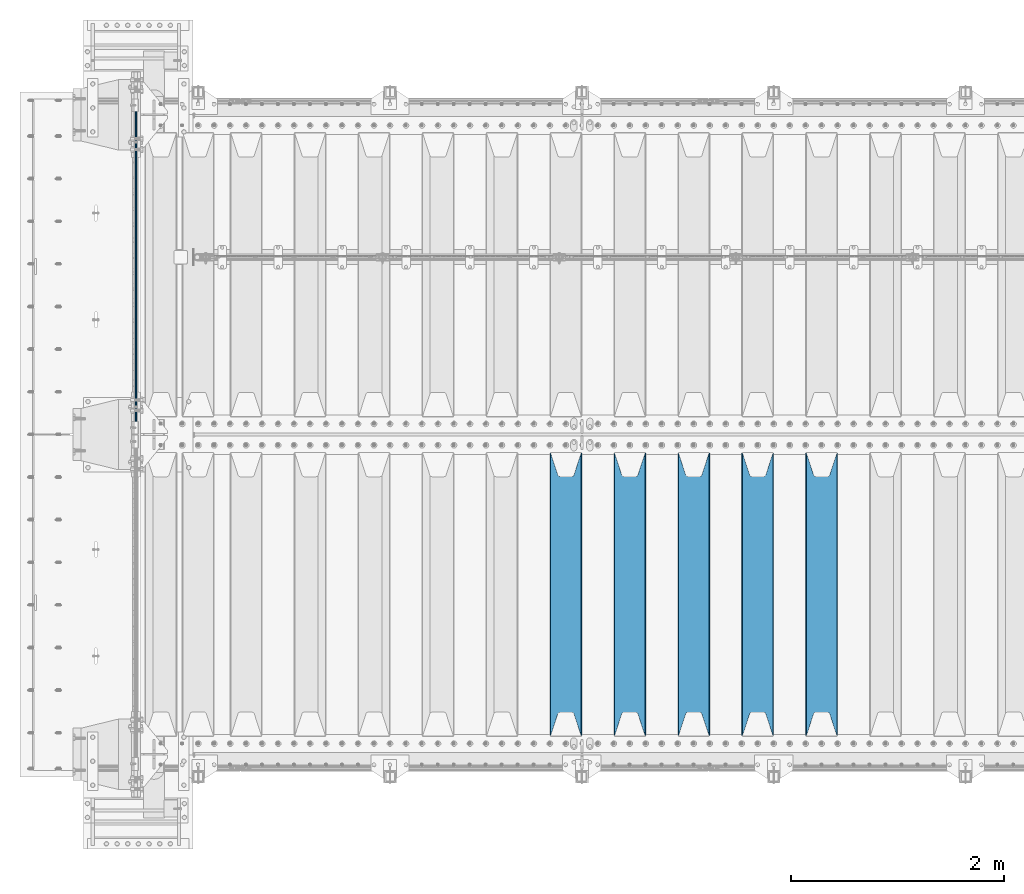
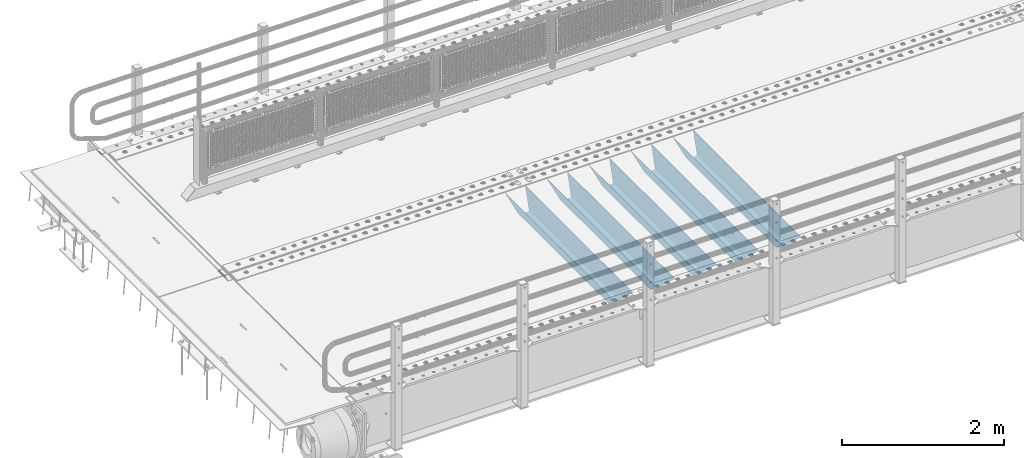
# One storey, part 87 of 193: 6 beams.
"""IFC2X3 building model written with IfcOpenShell, lengths in millimetres."""

from ifc_helpers import new_model, si_unit, frame, origin_with_axes, place, context, subcontext, project, spatial, faceted_brep, material, type_object, element, save


model = new_model("IFC2X3")

# Units and contexts
model_context = context("Model", 3, precision=1e-05, world=origin_with_axes())
body_context = subcontext(model_context, "Body", "Model", "MODEL_VIEW")
ifc_project = project(units=[si_unit("LENGTHUNIT", "METRE", prefix="MILLI"), si_unit("AREAUNIT", "SQUARE_METRE"), si_unit("VOLUMEUNIT", "CUBIC_METRE"), si_unit("MASSUNIT", "GRAM", prefix="KILO"), si_unit("TIMEUNIT", "SECOND"), si_unit("PLANEANGLEUNIT", "RADIAN"), si_unit("SOLIDANGLEUNIT", "STERADIAN"), si_unit("THERMODYNAMICTEMPERATUREUNIT", "DEGREE_CELSIUS"), si_unit("LUMINOUSINTENSITYUNIT", "LUMEN")], contexts=[model_context])

# Site, building, storey
site_placement = place(None, origin_with_axes())
site = spatial("IfcSite", under=ifc_project, at=site_placement, CompositionType="ELEMENT")
building_placement = place(site_placement, origin_with_axes())
building = spatial("IfcBuilding", under=site, at=building_placement, Name="Standard", CompositionType="ELEMENT")
storey_placement = place(building_placement, origin_with_axes())
storey = spatial("IfcBuildingStorey", under=building, at=storey_placement, Name="Undefined", CompositionType="ELEMENT", Elevation=0.0)

# Beams
ifc_material = material(Name="STEEL/S355N")
beam_type_1 = type_object("IfcBeamType", Name="D20", PredefinedType="NOTDEFINED")
beam_1_placement = place(storey_placement, frame((-42485.0, 27005.0, -25.9999999971316), z_axis=(0.0, 0.0, 1.0), x_axis=(0.0, 1.0, 0.0)))
element("IfcBeam", 1, at=beam_1_placement, inside=storey, type_object=beam_type_1, material=ifc_material, ObjectType="D20", context=body_context, shape_type="Brep", body=[
    faceted_brep([(0.0, -10.0, 0.0), (0.0, -7.07106781186303, -7.07106781186548), (3145.0, -7.07106781186303, -7.07106781186548), (3145.0, -10.0, 0.0), (0.0, 0.0, -10.0), (3145.0, 0.0, -10.0), (0.0, 7.07106781186303, -7.07106781186547), (3145.0, 7.07106781186303, -7.07106781186547), (0.0, 10.0, 0.0), (3145.0, 10.0, 0.0), (0.0, 7.07106781186303, 7.07106781186548), (3145.0, 7.07106781186303, 7.07106781186548), (0.0, 0.0, 10.0), (3145.0, 0.0, 10.0), (0.0, -7.07106781186303, 7.07106781186548), (3145.0, -7.07106781186303, 7.07106781186548)], [[[0, 1, 2, 3]], [[1, 4, 5, 2]], [[4, 6, 7, 5]], [[6, 8, 9, 7]], [[8, 10, 11, 9]], [[10, 12, 13, 11]], [[12, 14, 15, 13]], [[14, 0, 3, 15]], [[5, 7, 9, 11, 13, 15, 3, 2]], [[14, 12, 10, 8, 6, 4, 1, 0]]]),
])
beam_type_2 = type_object("IfcBeamType", PredefinedType="NOTDEFINED")
beam_2_placement = place(storey_placement, frame((-36050.0, 24175.0, -115.0), z_axis=(0.0, 0.0, 1.0), x_axis=(0.0, 1.0, 0.0)))
element("IfcBeam", 2, at=beam_2_placement, inside=storey, type_object=beam_type_2, material=ifc_material, context=body_context, shape_type="Brep", body=[
    faceted_brep([(0.0, 150.0, 115.0), (0.0, 143.689999999999, 115.0), (2650.00000000297, 143.689999999999, 115.0), (2650.00000000297, 150.0, 115.0), (2650.00000000297, 142.059565218398, 110.000000003094), (2650.00000000297, 148.3695652184, 110.000000003094), (2441.90079219209, -80.1103600731112, -98.0992078077845), (2437.7588105432, -77.5672621345584, -102.241189456673), (2434.06523489747, -74.4080125315522, -105.934765102404), (2430.9108609509, -70.710272125576, -109.089139048974), (2428.37322971128, -66.5649389910068, -111.626770288588), (2426.51472138055, -62.0739139532889, -113.485278619323), (2425.38102192092, -57.3475956567672, -114.618978078955), (2424.99999999988, -52.5021667386536, -115.0), (2424.99999999988, 52.5021667386536, -115.0), (2425.38102192092, 57.3475956567672, -114.618978078955), (2426.51472138055, 62.0739139532889, -113.485278619323), (2428.37322971128, 66.5649389910068, -111.626770288588), (2430.9108609509, 70.710272125576, -109.089139048974), (2434.06523489747, 74.4080125315522, -105.934765102404), (2437.7588105432, 77.5672621345584, -102.241189456673), (2441.90079219209, 80.1103600731112, -98.0992078077846), (2446.38936140512, 81.9747917625791, -93.6106385947584), (2448.2494850041, 76.2713538057251, -91.7505149957729), (2444.62967112263, 74.76777986261, -95.3703288772456), (2441.28936334127, 72.7168944282894, -98.710636658607), (2438.31067330439, 70.1691124903846, -101.689326695487), (2435.76682334748, 67.1870637758839, -104.233176652398), (2433.72034654134, 63.8440531834895, -106.279653458539), (2432.22154950042, 60.222258798236, -107.778450499454), (2431.30727574265, 56.4107117849089, -108.692724257221), (2430.99999999987, 52.5031078186876, -109.0), (2430.99999999987, -52.5031078186876, -109.0), (2431.30727574265, -56.4107117849089, -108.692724257221), (2432.22154950042, -60.222258798236, -107.778450499454), (2433.72034654134, -63.8440531834895, -106.279653458539), (2435.76682334748, -67.1870637758839, -104.233176652398), (2438.31067330439, -70.1691124903846, -101.689326695487), (2441.28936334127, -72.7168944282894, -98.7106366586071), (2444.62967112263, -74.76777986261, -95.3703288772457), (2448.2494850041, -76.2713538057251, -91.7505149957729), (2650.00000000297, -142.059565218398, 110.000000003094), (2650.00000000297, -148.3695652184, 110.000000003094), (2446.38936140512, -81.9747917625791, -93.6106385947584), (2650.00000000297, -143.689999999999, 115.0), (2650.00000000297, -150.0, 115.0), (0.0, -143.689999999999, 115.0), (0.0, -150.0, 115.0), (0.0, -148.369565218261, 110.000000002667), (203.610638597427, -81.9747917625791, -93.6106385947584), (208.099207810446, -80.1103600731112, -98.0992078077845), (212.241189459342, -77.5672621345584, -102.241189456673), (215.93476510507, -74.4080125315522, -105.934765102404), (219.089139051641, -70.710272125576, -109.089139048974), (221.626770291256, -66.5649389910068, -111.626770288588), (223.485278621989, -62.0739139532889, -113.485278619323), (224.618978081624, -57.3475956567672, -114.618978078955), (225.000000002663, -52.5021667386536, -115.0), (225.000000002663, 52.5021667386536, -115.0), (224.618978081624, 57.3475956567672, -114.618978078955), (223.485278621989, 62.0739139532889, -113.485278619323), (221.626770291256, 66.5649389910068, -111.626770288588), (219.089139051641, 70.710272125576, -109.089139048974), (215.93476510507, 74.4080125315522, -105.934765102404), (212.241189459342, 77.5672621345584, -102.241189456673), (208.099207810446, 80.1103600731112, -98.0992078077846), (203.610638597427, 81.9747917625791, -93.6106385947584), (0.0, 148.369565218261, 110.000000002667), (0.0, 142.05956521826, 110.000000002667), (201.750514998439, 76.2713538057251, -91.7505149957729), (205.370328879915, 74.76777986261, -95.3703288772456), (208.710636661275, 72.7168944282894, -98.710636658607), (211.689326698157, 70.1691124903846, -101.689326695487), (214.233176655063, 67.1870637758839, -104.233176652398), (216.279653461206, 63.8440531834895, -106.279653458539), (217.778450502123, 60.222258798236, -107.778450499454), (218.69272425989, 56.4107117849089, -108.692724257221), (219.00000000267, 52.5031078186876, -109.0), (219.00000000267, -52.5031078186876, -109.0), (218.69272425989, -56.4107117849089, -108.692724257221), (217.778450502123, -60.222258798236, -107.778450499454), (216.279653461206, -63.8440531834895, -106.279653458539), (214.233176655063, -67.1870637758839, -104.233176652398), (211.689326698157, -70.1691124903846, -101.689326695487), (208.710636661275, -72.7168944282894, -98.7106366586071), (205.370328879915, -74.76777986261, -95.3703288772457), (201.750514998439, -76.2713538057251, -91.7505149957729), (0.0, -142.05956521826, 110.000000002667)], [[[0, 1, 2, 3]], [[3, 2, 4, 5]], [[6, 7, 8, 9, 10, 11, 12, 13, 14, 15, 16, 17, 18, 19, 20, 21, 22, 5, 4, 23, 24, 25, 26, 27, 28, 29, 30, 31, 32, 33, 34, 35, 36, 37, 38, 39, 40, 41, 42, 43]], [[44, 45, 42, 41]], [[46, 47, 45, 44]], [[43, 42, 45, 47, 48, 49]], [[6, 43, 49, 50]], [[7, 6, 50, 51]], [[8, 7, 51, 52]], [[9, 8, 52, 53]], [[10, 9, 53, 54]], [[11, 10, 54, 55]], [[12, 11, 55, 56]], [[13, 12, 56, 57]], [[14, 13, 57, 58]], [[15, 14, 58, 59]], [[16, 15, 59, 60]], [[17, 16, 60, 61]], [[18, 17, 61, 62]], [[19, 18, 62, 63]], [[20, 19, 63, 64]], [[21, 20, 64, 65]], [[22, 21, 65, 66]], [[0, 3, 5, 22, 66, 67]], [[1, 0, 67, 68]], [[23, 4, 2, 1, 68, 69]], [[24, 23, 69, 70]], [[25, 24, 70, 71]], [[26, 25, 71, 72]], [[27, 26, 72, 73]], [[28, 27, 73, 74]], [[29, 28, 74, 75]], [[30, 29, 75, 76]], [[31, 30, 76, 77]], [[32, 31, 77, 78]], [[33, 32, 78, 79]], [[34, 33, 79, 80]], [[35, 34, 80, 81]], [[36, 35, 81, 82]], [[37, 36, 82, 83]], [[38, 37, 83, 84]], [[39, 38, 84, 85]], [[40, 39, 85, 86]], [[46, 44, 41, 40, 86, 87]], [[47, 46, 87, 48]], [[86, 85, 84, 83, 82, 81, 80, 79, 78, 77, 76, 75, 74, 73, 72, 71, 70, 69, 68, 67, 66, 65, 64, 63, 62, 61, 60, 59, 58, 57, 56, 55, 54, 53, 52, 51, 50, 49, 48, 87]]]),
])
beam_3_placement = place(storey_placement, frame((-36650.0, 24175.0, -115.0), z_axis=(0.0, 0.0, 1.0), x_axis=(0.0, 1.0, 0.0)))
element("IfcBeam", 3, at=beam_3_placement, inside=storey, type_object=beam_type_2, material=ifc_material, context=body_context, shape_type="Brep", body=[
    faceted_brep([(0.0, 150.0, 115.0), (0.0, 143.689999999999, 115.0), (2650.00000000297, 143.689999999999, 115.0), (2650.00000000297, 150.0, 115.0), (2650.00000000297, 142.059565218398, 110.000000003094), (2650.00000000297, 148.3695652184, 110.000000003094), (2441.90079219209, -80.1103600731112, -98.0992078077845), (2437.7588105432, -77.5672621345584, -102.241189456673), (2434.06523489747, -74.4080125315522, -105.934765102404), (2430.9108609509, -70.710272125576, -109.089139048974), (2428.37322971128, -66.5649389910068, -111.626770288588), (2426.51472138055, -62.0739139532889, -113.485278619323), (2425.38102192092, -57.3475956567672, -114.618978078955), (2424.99999999988, -52.5021667386536, -115.0), (2424.99999999988, 52.5021667386536, -115.0), (2425.38102192092, 57.3475956567672, -114.618978078955), (2426.51472138055, 62.0739139532889, -113.485278619323), (2428.37322971128, 66.5649389910068, -111.626770288588), (2430.9108609509, 70.710272125576, -109.089139048974), (2434.06523489747, 74.4080125315522, -105.934765102404), (2437.7588105432, 77.5672621345584, -102.241189456673), (2441.90079219209, 80.1103600731112, -98.0992078077846), (2446.38936140512, 81.9747917625791, -93.6106385947584), (2448.2494850041, 76.2713538057251, -91.7505149957729), (2444.62967112263, 74.76777986261, -95.3703288772456), (2441.28936334127, 72.7168944282894, -98.710636658607), (2438.31067330439, 70.1691124903846, -101.689326695487), (2435.76682334748, 67.1870637758839, -104.233176652398), (2433.72034654134, 63.8440531834895, -106.279653458539), (2432.22154950042, 60.222258798236, -107.778450499454), (2431.30727574265, 56.4107117849089, -108.692724257221), (2430.99999999987, 52.5031078186876, -109.0), (2430.99999999987, -52.5031078186876, -109.0), (2431.30727574265, -56.4107117849089, -108.692724257221), (2432.22154950042, -60.222258798236, -107.778450499454), (2433.72034654134, -63.8440531834895, -106.279653458539), (2435.76682334748, -67.1870637758839, -104.233176652398), (2438.31067330439, -70.1691124903846, -101.689326695487), (2441.28936334127, -72.7168944282894, -98.7106366586071), (2444.62967112263, -74.76777986261, -95.3703288772457), (2448.2494850041, -76.2713538057251, -91.7505149957729), (2650.00000000297, -142.059565218398, 110.000000003094), (2650.00000000297, -148.3695652184, 110.000000003094), (2446.38936140512, -81.9747917625791, -93.6106385947584), (2650.00000000297, -143.689999999999, 115.0), (2650.00000000297, -150.0, 115.0), (0.0, -143.689999999999, 115.0), (0.0, -150.0, 115.0), (0.0, -148.369565218261, 110.000000002667), (203.610638597427, -81.9747917625791, -93.6106385947584), (208.099207810446, -80.1103600731112, -98.0992078077845), (212.241189459342, -77.5672621345584, -102.241189456673), (215.93476510507, -74.4080125315522, -105.934765102404), (219.089139051641, -70.710272125576, -109.089139048974), (221.626770291256, -66.5649389910068, -111.626770288588), (223.485278621989, -62.0739139532889, -113.485278619323), (224.618978081624, -57.3475956567672, -114.618978078955), (225.000000002663, -52.5021667386536, -115.0), (225.000000002663, 52.5021667386536, -115.0), (224.618978081624, 57.3475956567672, -114.618978078955), (223.485278621989, 62.0739139532889, -113.485278619323), (221.626770291256, 66.5649389910068, -111.626770288588), (219.089139051641, 70.710272125576, -109.089139048974), (215.93476510507, 74.4080125315522, -105.934765102404), (212.241189459342, 77.5672621345584, -102.241189456673), (208.099207810446, 80.1103600731112, -98.0992078077846), (203.610638597427, 81.9747917625791, -93.6106385947584), (0.0, 148.369565218261, 110.000000002667), (0.0, 142.05956521826, 110.000000002667), (201.750514998439, 76.2713538057251, -91.7505149957729), (205.370328879915, 74.76777986261, -95.3703288772456), (208.710636661275, 72.7168944282894, -98.710636658607), (211.689326698157, 70.1691124903846, -101.689326695487), (214.233176655063, 67.1870637758839, -104.233176652398), (216.279653461206, 63.8440531834895, -106.279653458539), (217.778450502123, 60.222258798236, -107.778450499454), (218.69272425989, 56.4107117849089, -108.692724257221), (219.00000000267, 52.5031078186876, -109.0), (219.00000000267, -52.5031078186876, -109.0), (218.69272425989, -56.4107117849089, -108.692724257221), (217.778450502123, -60.222258798236, -107.778450499454), (216.279653461206, -63.8440531834895, -106.279653458539), (214.233176655063, -67.1870637758839, -104.233176652398), (211.689326698157, -70.1691124903846, -101.689326695487), (208.710636661275, -72.7168944282894, -98.7106366586071), (205.370328879915, -74.76777986261, -95.3703288772457), (201.750514998439, -76.2713538057251, -91.7505149957729), (0.0, -142.05956521826, 110.000000002667)], [[[0, 1, 2, 3]], [[3, 2, 4, 5]], [[6, 7, 8, 9, 10, 11, 12, 13, 14, 15, 16, 17, 18, 19, 20, 21, 22, 5, 4, 23, 24, 25, 26, 27, 28, 29, 30, 31, 32, 33, 34, 35, 36, 37, 38, 39, 40, 41, 42, 43]], [[44, 45, 42, 41]], [[46, 47, 45, 44]], [[43, 42, 45, 47, 48, 49]], [[6, 43, 49, 50]], [[7, 6, 50, 51]], [[8, 7, 51, 52]], [[9, 8, 52, 53]], [[10, 9, 53, 54]], [[11, 10, 54, 55]], [[12, 11, 55, 56]], [[13, 12, 56, 57]], [[14, 13, 57, 58]], [[15, 14, 58, 59]], [[16, 15, 59, 60]], [[17, 16, 60, 61]], [[18, 17, 61, 62]], [[19, 18, 62, 63]], [[20, 19, 63, 64]], [[21, 20, 64, 65]], [[22, 21, 65, 66]], [[0, 3, 5, 22, 66, 67]], [[1, 0, 67, 68]], [[23, 4, 2, 1, 68, 69]], [[24, 23, 69, 70]], [[25, 24, 70, 71]], [[26, 25, 71, 72]], [[27, 26, 72, 73]], [[28, 27, 73, 74]], [[29, 28, 74, 75]], [[30, 29, 75, 76]], [[31, 30, 76, 77]], [[32, 31, 77, 78]], [[33, 32, 78, 79]], [[34, 33, 79, 80]], [[35, 34, 80, 81]], [[36, 35, 81, 82]], [[37, 36, 82, 83]], [[38, 37, 83, 84]], [[39, 38, 84, 85]], [[40, 39, 85, 86]], [[46, 44, 41, 40, 86, 87]], [[47, 46, 87, 48]], [[86, 85, 84, 83, 82, 81, 80, 79, 78, 77, 76, 75, 74, 73, 72, 71, 70, 69, 68, 67, 66, 65, 64, 63, 62, 61, 60, 59, 58, 57, 56, 55, 54, 53, 52, 51, 50, 49, 48, 87]]]),
])
beam_4_placement = place(storey_placement, frame((-37250.0, 24175.0, -115.0), z_axis=(0.0, 0.0, 1.0), x_axis=(0.0, 1.0, 0.0)))
element("IfcBeam", 4, at=beam_4_placement, inside=storey, type_object=beam_type_2, material=ifc_material, context=body_context, shape_type="Brep", body=[
    faceted_brep([(0.0, 150.0, 115.0), (0.0, 143.689999999999, 115.0), (2650.00000000297, 143.689999999999, 115.0), (2650.00000000297, 150.0, 115.0), (2650.00000000297, 142.059565218398, 110.000000003094), (2650.00000000297, 148.3695652184, 110.000000003094), (2441.90079219209, -80.1103600731112, -98.0992078077845), (2437.7588105432, -77.5672621345584, -102.241189456673), (2434.06523489747, -74.4080125315522, -105.934765102404), (2430.9108609509, -70.710272125576, -109.089139048974), (2428.37322971128, -66.5649389910068, -111.626770288588), (2426.51472138055, -62.0739139532889, -113.485278619323), (2425.38102192092, -57.3475956567672, -114.618978078955), (2424.99999999988, -52.5021667386536, -115.0), (2424.99999999988, 52.5021667386536, -115.0), (2425.38102192092, 57.3475956567672, -114.618978078955), (2426.51472138055, 62.0739139532889, -113.485278619323), (2428.37322971128, 66.5649389910068, -111.626770288588), (2430.9108609509, 70.710272125576, -109.089139048974), (2434.06523489747, 74.4080125315522, -105.934765102404), (2437.7588105432, 77.5672621345584, -102.241189456673), (2441.90079219209, 80.1103600731112, -98.0992078077846), (2446.38936140512, 81.9747917625791, -93.6106385947584), (2448.2494850041, 76.2713538057251, -91.7505149957729), (2444.62967112263, 74.76777986261, -95.3703288772456), (2441.28936334127, 72.7168944282894, -98.710636658607), (2438.31067330439, 70.1691124903846, -101.689326695487), (2435.76682334748, 67.1870637758839, -104.233176652398), (2433.72034654134, 63.8440531834895, -106.279653458539), (2432.22154950042, 60.222258798236, -107.778450499454), (2431.30727574265, 56.4107117849089, -108.692724257221), (2430.99999999987, 52.5031078186876, -109.0), (2430.99999999987, -52.5031078186876, -109.0), (2431.30727574265, -56.4107117849089, -108.692724257221), (2432.22154950042, -60.222258798236, -107.778450499454), (2433.72034654134, -63.8440531834895, -106.279653458539), (2435.76682334748, -67.1870637758839, -104.233176652398), (2438.31067330439, -70.1691124903846, -101.689326695487), (2441.28936334127, -72.7168944282894, -98.7106366586071), (2444.62967112263, -74.76777986261, -95.3703288772457), (2448.2494850041, -76.2713538057251, -91.7505149957729), (2650.00000000297, -142.059565218398, 110.000000003094), (2650.00000000297, -148.3695652184, 110.000000003094), (2446.38936140512, -81.9747917625791, -93.6106385947584), (2650.00000000297, -143.689999999999, 115.0), (2650.00000000297, -150.0, 115.0), (0.0, -143.689999999999, 115.0), (0.0, -150.0, 115.0), (0.0, -148.369565218261, 110.000000002667), (203.610638597427, -81.9747917625791, -93.6106385947584), (208.099207810446, -80.1103600731112, -98.0992078077845), (212.241189459342, -77.5672621345584, -102.241189456673), (215.93476510507, -74.4080125315522, -105.934765102404), (219.089139051641, -70.710272125576, -109.089139048974), (221.626770291256, -66.5649389910068, -111.626770288588), (223.485278621989, -62.0739139532889, -113.485278619323), (224.618978081624, -57.3475956567672, -114.618978078955), (225.000000002663, -52.5021667386536, -115.0), (225.000000002663, 52.5021667386536, -115.0), (224.618978081624, 57.3475956567672, -114.618978078955), (223.485278621989, 62.0739139532889, -113.485278619323), (221.626770291256, 66.5649389910068, -111.626770288588), (219.089139051641, 70.710272125576, -109.089139048974), (215.93476510507, 74.4080125315522, -105.934765102404), (212.241189459342, 77.5672621345584, -102.241189456673), (208.099207810446, 80.1103600731112, -98.0992078077846), (203.610638597427, 81.9747917625791, -93.6106385947584), (0.0, 148.369565218261, 110.000000002667), (0.0, 142.05956521826, 110.000000002667), (201.750514998439, 76.2713538057251, -91.7505149957729), (205.370328879915, 74.76777986261, -95.3703288772456), (208.710636661275, 72.7168944282894, -98.710636658607), (211.689326698157, 70.1691124903846, -101.689326695487), (214.233176655063, 67.1870637758839, -104.233176652398), (216.279653461206, 63.8440531834895, -106.279653458539), (217.778450502123, 60.222258798236, -107.778450499454), (218.69272425989, 56.4107117849089, -108.692724257221), (219.00000000267, 52.5031078186876, -109.0), (219.00000000267, -52.5031078186876, -109.0), (218.69272425989, -56.4107117849089, -108.692724257221), (217.778450502123, -60.222258798236, -107.778450499454), (216.279653461206, -63.8440531834895, -106.279653458539), (214.233176655063, -67.1870637758839, -104.233176652398), (211.689326698157, -70.1691124903846, -101.689326695487), (208.710636661275, -72.7168944282894, -98.7106366586071), (205.370328879915, -74.76777986261, -95.3703288772457), (201.750514998439, -76.2713538057251, -91.7505149957729), (0.0, -142.05956521826, 110.000000002667)], [[[0, 1, 2, 3]], [[3, 2, 4, 5]], [[6, 7, 8, 9, 10, 11, 12, 13, 14, 15, 16, 17, 18, 19, 20, 21, 22, 5, 4, 23, 24, 25, 26, 27, 28, 29, 30, 31, 32, 33, 34, 35, 36, 37, 38, 39, 40, 41, 42, 43]], [[44, 45, 42, 41]], [[46, 47, 45, 44]], [[43, 42, 45, 47, 48, 49]], [[6, 43, 49, 50]], [[7, 6, 50, 51]], [[8, 7, 51, 52]], [[9, 8, 52, 53]], [[10, 9, 53, 54]], [[11, 10, 54, 55]], [[12, 11, 55, 56]], [[13, 12, 56, 57]], [[14, 13, 57, 58]], [[15, 14, 58, 59]], [[16, 15, 59, 60]], [[17, 16, 60, 61]], [[18, 17, 61, 62]], [[19, 18, 62, 63]], [[20, 19, 63, 64]], [[21, 20, 64, 65]], [[22, 21, 65, 66]], [[0, 3, 5, 22, 66, 67]], [[1, 0, 67, 68]], [[23, 4, 2, 1, 68, 69]], [[24, 23, 69, 70]], [[25, 24, 70, 71]], [[26, 25, 71, 72]], [[27, 26, 72, 73]], [[28, 27, 73, 74]], [[29, 28, 74, 75]], [[30, 29, 75, 76]], [[31, 30, 76, 77]], [[32, 31, 77, 78]], [[33, 32, 78, 79]], [[34, 33, 79, 80]], [[35, 34, 80, 81]], [[36, 35, 81, 82]], [[37, 36, 82, 83]], [[38, 37, 83, 84]], [[39, 38, 84, 85]], [[40, 39, 85, 86]], [[46, 44, 41, 40, 86, 87]], [[47, 46, 87, 48]], [[86, 85, 84, 83, 82, 81, 80, 79, 78, 77, 76, 75, 74, 73, 72, 71, 70, 69, 68, 67, 66, 65, 64, 63, 62, 61, 60, 59, 58, 57, 56, 55, 54, 53, 52, 51, 50, 49, 48, 87]]]),
])
beam_5_placement = place(storey_placement, frame((-37850.0, 24175.0, -115.0), z_axis=(0.0, 0.0, 1.0), x_axis=(0.0, 1.0, 0.0)))
element("IfcBeam", 5, at=beam_5_placement, inside=storey, type_object=beam_type_2, material=ifc_material, context=body_context, shape_type="Brep", body=[
    faceted_brep([(0.0, 150.0, 115.0), (0.0, 143.689999999999, 115.0), (2650.00000000297, 143.689999999999, 115.0), (2650.00000000297, 150.0, 115.0), (2650.00000000297, 142.059565218398, 110.000000003094), (2650.00000000297, 148.3695652184, 110.000000003094), (2441.90079219209, -80.1103600731112, -98.0992078077845), (2437.7588105432, -77.5672621345584, -102.241189456673), (2434.06523489747, -74.4080125315522, -105.934765102404), (2430.9108609509, -70.710272125576, -109.089139048974), (2428.37322971128, -66.5649389910068, -111.626770288588), (2426.51472138055, -62.0739139532889, -113.485278619323), (2425.38102192092, -57.3475956567672, -114.618978078955), (2424.99999999988, -52.5021667386536, -115.0), (2424.99999999988, 52.5021667386536, -115.0), (2425.38102192092, 57.3475956567672, -114.618978078955), (2426.51472138055, 62.0739139532889, -113.485278619323), (2428.37322971128, 66.5649389910068, -111.626770288588), (2430.9108609509, 70.710272125576, -109.089139048974), (2434.06523489747, 74.4080125315522, -105.934765102404), (2437.7588105432, 77.5672621345584, -102.241189456673), (2441.90079219209, 80.1103600731112, -98.0992078077846), (2446.38936140512, 81.9747917625791, -93.6106385947584), (2448.2494850041, 76.2713538057251, -91.7505149957729), (2444.62967112263, 74.76777986261, -95.3703288772456), (2441.28936334127, 72.7168944282894, -98.710636658607), (2438.31067330439, 70.1691124903846, -101.689326695487), (2435.76682334748, 67.1870637758839, -104.233176652398), (2433.72034654134, 63.8440531834895, -106.279653458539), (2432.22154950042, 60.222258798236, -107.778450499454), (2431.30727574265, 56.4107117849089, -108.692724257221), (2430.99999999987, 52.5031078186876, -109.0), (2430.99999999987, -52.5031078186876, -109.0), (2431.30727574265, -56.4107117849089, -108.692724257221), (2432.22154950042, -60.222258798236, -107.778450499454), (2433.72034654134, -63.8440531834895, -106.279653458539), (2435.76682334748, -67.1870637758839, -104.233176652398), (2438.31067330439, -70.1691124903846, -101.689326695487), (2441.28936334127, -72.7168944282894, -98.7106366586071), (2444.62967112263, -74.76777986261, -95.3703288772457), (2448.2494850041, -76.2713538057251, -91.7505149957729), (2650.00000000297, -142.059565218398, 110.000000003094), (2650.00000000297, -148.3695652184, 110.000000003094), (2446.38936140512, -81.9747917625791, -93.6106385947584), (2650.00000000297, -143.689999999999, 115.0), (2650.00000000297, -150.0, 115.0), (0.0, -143.689999999999, 115.0), (0.0, -150.0, 115.0), (0.0, -148.369565218261, 110.000000002667), (203.610638597427, -81.9747917625791, -93.6106385947584), (208.099207810446, -80.1103600731112, -98.0992078077845), (212.241189459342, -77.5672621345584, -102.241189456673), (215.93476510507, -74.4080125315522, -105.934765102404), (219.089139051641, -70.710272125576, -109.089139048974), (221.626770291256, -66.5649389910068, -111.626770288588), (223.485278621989, -62.0739139532889, -113.485278619323), (224.618978081624, -57.3475956567672, -114.618978078955), (225.000000002663, -52.5021667386536, -115.0), (225.000000002663, 52.5021667386536, -115.0), (224.618978081624, 57.3475956567672, -114.618978078955), (223.485278621989, 62.0739139532889, -113.485278619323), (221.626770291256, 66.5649389910068, -111.626770288588), (219.089139051641, 70.710272125576, -109.089139048974), (215.93476510507, 74.4080125315522, -105.934765102404), (212.241189459342, 77.5672621345584, -102.241189456673), (208.099207810446, 80.1103600731112, -98.0992078077846), (203.610638597427, 81.9747917625791, -93.6106385947584), (0.0, 148.369565218261, 110.000000002667), (0.0, 142.05956521826, 110.000000002667), (201.750514998439, 76.2713538057251, -91.7505149957729), (205.370328879915, 74.76777986261, -95.3703288772456), (208.710636661275, 72.7168944282894, -98.710636658607), (211.689326698157, 70.1691124903846, -101.689326695487), (214.233176655063, 67.1870637758839, -104.233176652398), (216.279653461206, 63.8440531834895, -106.279653458539), (217.778450502123, 60.222258798236, -107.778450499454), (218.69272425989, 56.4107117849089, -108.692724257221), (219.00000000267, 52.5031078186876, -109.0), (219.00000000267, -52.5031078186876, -109.0), (218.69272425989, -56.4107117849089, -108.692724257221), (217.778450502123, -60.222258798236, -107.778450499454), (216.279653461206, -63.8440531834895, -106.279653458539), (214.233176655063, -67.1870637758839, -104.233176652398), (211.689326698157, -70.1691124903846, -101.689326695487), (208.710636661275, -72.7168944282894, -98.7106366586071), (205.370328879915, -74.76777986261, -95.3703288772457), (201.750514998439, -76.2713538057251, -91.7505149957729), (0.0, -142.05956521826, 110.000000002667)], [[[0, 1, 2, 3]], [[3, 2, 4, 5]], [[6, 7, 8, 9, 10, 11, 12, 13, 14, 15, 16, 17, 18, 19, 20, 21, 22, 5, 4, 23, 24, 25, 26, 27, 28, 29, 30, 31, 32, 33, 34, 35, 36, 37, 38, 39, 40, 41, 42, 43]], [[44, 45, 42, 41]], [[46, 47, 45, 44]], [[43, 42, 45, 47, 48, 49]], [[6, 43, 49, 50]], [[7, 6, 50, 51]], [[8, 7, 51, 52]], [[9, 8, 52, 53]], [[10, 9, 53, 54]], [[11, 10, 54, 55]], [[12, 11, 55, 56]], [[13, 12, 56, 57]], [[14, 13, 57, 58]], [[15, 14, 58, 59]], [[16, 15, 59, 60]], [[17, 16, 60, 61]], [[18, 17, 61, 62]], [[19, 18, 62, 63]], [[20, 19, 63, 64]], [[21, 20, 64, 65]], [[22, 21, 65, 66]], [[0, 3, 5, 22, 66, 67]], [[1, 0, 67, 68]], [[23, 4, 2, 1, 68, 69]], [[24, 23, 69, 70]], [[25, 24, 70, 71]], [[26, 25, 71, 72]], [[27, 26, 72, 73]], [[28, 27, 73, 74]], [[29, 28, 74, 75]], [[30, 29, 75, 76]], [[31, 30, 76, 77]], [[32, 31, 77, 78]], [[33, 32, 78, 79]], [[34, 33, 79, 80]], [[35, 34, 80, 81]], [[36, 35, 81, 82]], [[37, 36, 82, 83]], [[38, 37, 83, 84]], [[39, 38, 84, 85]], [[40, 39, 85, 86]], [[46, 44, 41, 40, 86, 87]], [[47, 46, 87, 48]], [[86, 85, 84, 83, 82, 81, 80, 79, 78, 77, 76, 75, 74, 73, 72, 71, 70, 69, 68, 67, 66, 65, 64, 63, 62, 61, 60, 59, 58, 57, 56, 55, 54, 53, 52, 51, 50, 49, 48, 87]]]),
])
beam_6_placement = place(storey_placement, frame((-38450.0, 24175.0, -115.0), z_axis=(0.0, 0.0, 1.0), x_axis=(0.0, 1.0, 0.0)))
element("IfcBeam", 6, at=beam_6_placement, inside=storey, type_object=beam_type_2, material=ifc_material, context=body_context, shape_type="Brep", body=[
    faceted_brep([(0.0, 150.0, 115.0), (0.0, 143.689999999999, 115.0), (2650.00000000297, 143.689999999999, 115.0), (2650.00000000297, 150.0, 115.0), (2650.00000000297, 142.059565218398, 110.000000003094), (2650.00000000297, 148.3695652184, 110.000000003094), (2441.90079219209, -80.1103600731112, -98.0992078077845), (2437.7588105432, -77.5672621345584, -102.241189456673), (2434.06523489747, -74.4080125315522, -105.934765102404), (2430.9108609509, -70.710272125576, -109.089139048974), (2428.37322971128, -66.5649389910068, -111.626770288588), (2426.51472138055, -62.0739139532889, -113.485278619323), (2425.38102192092, -57.3475956567672, -114.618978078955), (2424.99999999988, -52.5021667386536, -115.0), (2424.99999999988, 52.5021667386536, -115.0), (2425.38102192092, 57.3475956567672, -114.618978078955), (2426.51472138055, 62.0739139532889, -113.485278619323), (2428.37322971128, 66.5649389910068, -111.626770288588), (2430.9108609509, 70.710272125576, -109.089139048974), (2434.06523489747, 74.4080125315522, -105.934765102404), (2437.7588105432, 77.5672621345584, -102.241189456673), (2441.90079219209, 80.1103600731112, -98.0992078077846), (2446.38936140512, 81.9747917625791, -93.6106385947584), (2448.2494850041, 76.2713538057251, -91.7505149957729), (2444.62967112263, 74.76777986261, -95.3703288772456), (2441.28936334127, 72.7168944282894, -98.710636658607), (2438.31067330439, 70.1691124903846, -101.689326695487), (2435.76682334748, 67.1870637758839, -104.233176652398), (2433.72034654134, 63.8440531834895, -106.279653458539), (2432.22154950042, 60.222258798236, -107.778450499454), (2431.30727574265, 56.4107117849089, -108.692724257221), (2430.99999999987, 52.5031078186876, -109.0), (2430.99999999987, -52.5031078186876, -109.0), (2431.30727574265, -56.4107117849089, -108.692724257221), (2432.22154950042, -60.222258798236, -107.778450499454), (2433.72034654134, -63.8440531834895, -106.279653458539), (2435.76682334748, -67.1870637758839, -104.233176652398), (2438.31067330439, -70.1691124903846, -101.689326695487), (2441.28936334127, -72.7168944282894, -98.7106366586071), (2444.62967112263, -74.76777986261, -95.3703288772457), (2448.2494850041, -76.2713538057251, -91.7505149957729), (2650.00000000297, -142.059565218398, 110.000000003094), (2650.00000000297, -148.3695652184, 110.000000003094), (2446.38936140512, -81.9747917625791, -93.6106385947584), (2650.00000000297, -143.689999999999, 115.0), (2650.00000000297, -150.0, 115.0), (0.0, -143.689999999999, 115.0), (0.0, -150.0, 115.0), (0.0, -148.369565218261, 110.000000002667), (203.610638597427, -81.9747917625791, -93.6106385947584), (208.099207810446, -80.1103600731112, -98.0992078077845), (212.241189459342, -77.5672621345584, -102.241189456673), (215.93476510507, -74.4080125315522, -105.934765102404), (219.089139051641, -70.710272125576, -109.089139048974), (221.626770291256, -66.5649389910068, -111.626770288588), (223.485278621989, -62.0739139532889, -113.485278619323), (224.618978081624, -57.3475956567672, -114.618978078955), (225.000000002663, -52.5021667386536, -115.0), (225.000000002663, 52.5021667386536, -115.0), (224.618978081624, 57.3475956567672, -114.618978078955), (223.485278621989, 62.0739139532889, -113.485278619323), (221.626770291256, 66.5649389910068, -111.626770288588), (219.089139051641, 70.710272125576, -109.089139048974), (215.93476510507, 74.4080125315522, -105.934765102404), (212.241189459342, 77.5672621345584, -102.241189456673), (208.099207810446, 80.1103600731112, -98.0992078077846), (203.610638597427, 81.9747917625791, -93.6106385947584), (0.0, 148.369565218261, 110.000000002667), (0.0, 142.05956521826, 110.000000002667), (201.750514998439, 76.2713538057251, -91.7505149957729), (205.370328879915, 74.76777986261, -95.3703288772456), (208.710636661275, 72.7168944282894, -98.710636658607), (211.689326698157, 70.1691124903846, -101.689326695487), (214.233176655063, 67.1870637758839, -104.233176652398), (216.279653461206, 63.8440531834895, -106.279653458539), (217.778450502123, 60.222258798236, -107.778450499454), (218.69272425989, 56.4107117849089, -108.692724257221), (219.00000000267, 52.5031078186876, -109.0), (219.00000000267, -52.5031078186876, -109.0), (218.69272425989, -56.4107117849089, -108.692724257221), (217.778450502123, -60.222258798236, -107.778450499454), (216.279653461206, -63.8440531834895, -106.279653458539), (214.233176655063, -67.1870637758839, -104.233176652398), (211.689326698157, -70.1691124903846, -101.689326695487), (208.710636661275, -72.7168944282894, -98.7106366586071), (205.370328879915, -74.76777986261, -95.3703288772457), (201.750514998439, -76.2713538057251, -91.7505149957729), (0.0, -142.05956521826, 110.000000002667)], [[[0, 1, 2, 3]], [[3, 2, 4, 5]], [[6, 7, 8, 9, 10, 11, 12, 13, 14, 15, 16, 17, 18, 19, 20, 21, 22, 5, 4, 23, 24, 25, 26, 27, 28, 29, 30, 31, 32, 33, 34, 35, 36, 37, 38, 39, 40, 41, 42, 43]], [[44, 45, 42, 41]], [[46, 47, 45, 44]], [[43, 42, 45, 47, 48, 49]], [[6, 43, 49, 50]], [[7, 6, 50, 51]], [[8, 7, 51, 52]], [[9, 8, 52, 53]], [[10, 9, 53, 54]], [[11, 10, 54, 55]], [[12, 11, 55, 56]], [[13, 12, 56, 57]], [[14, 13, 57, 58]], [[15, 14, 58, 59]], [[16, 15, 59, 60]], [[17, 16, 60, 61]], [[18, 17, 61, 62]], [[19, 18, 62, 63]], [[20, 19, 63, 64]], [[21, 20, 64, 65]], [[22, 21, 65, 66]], [[0, 3, 5, 22, 66, 67]], [[1, 0, 67, 68]], [[23, 4, 2, 1, 68, 69]], [[24, 23, 69, 70]], [[25, 24, 70, 71]], [[26, 25, 71, 72]], [[27, 26, 72, 73]], [[28, 27, 73, 74]], [[29, 28, 74, 75]], [[30, 29, 75, 76]], [[31, 30, 76, 77]], [[32, 31, 77, 78]], [[33, 32, 78, 79]], [[34, 33, 79, 80]], [[35, 34, 80, 81]], [[36, 35, 81, 82]], [[37, 36, 82, 83]], [[38, 37, 83, 84]], [[39, 38, 84, 85]], [[40, 39, 85, 86]], [[46, 44, 41, 40, 86, 87]], [[47, 46, 87, 48]], [[86, 85, 84, 83, 82, 81, 80, 79, 78, 77, 76, 75, 74, 73, 72, 71, 70, 69, 68, 67, 66, 65, 64, 63, 62, 61, 60, 59, 58, 57, 56, 55, 54, 53, 52, 51, 50, 49, 48, 87]]]),
])

save(model, "model.ifc")
